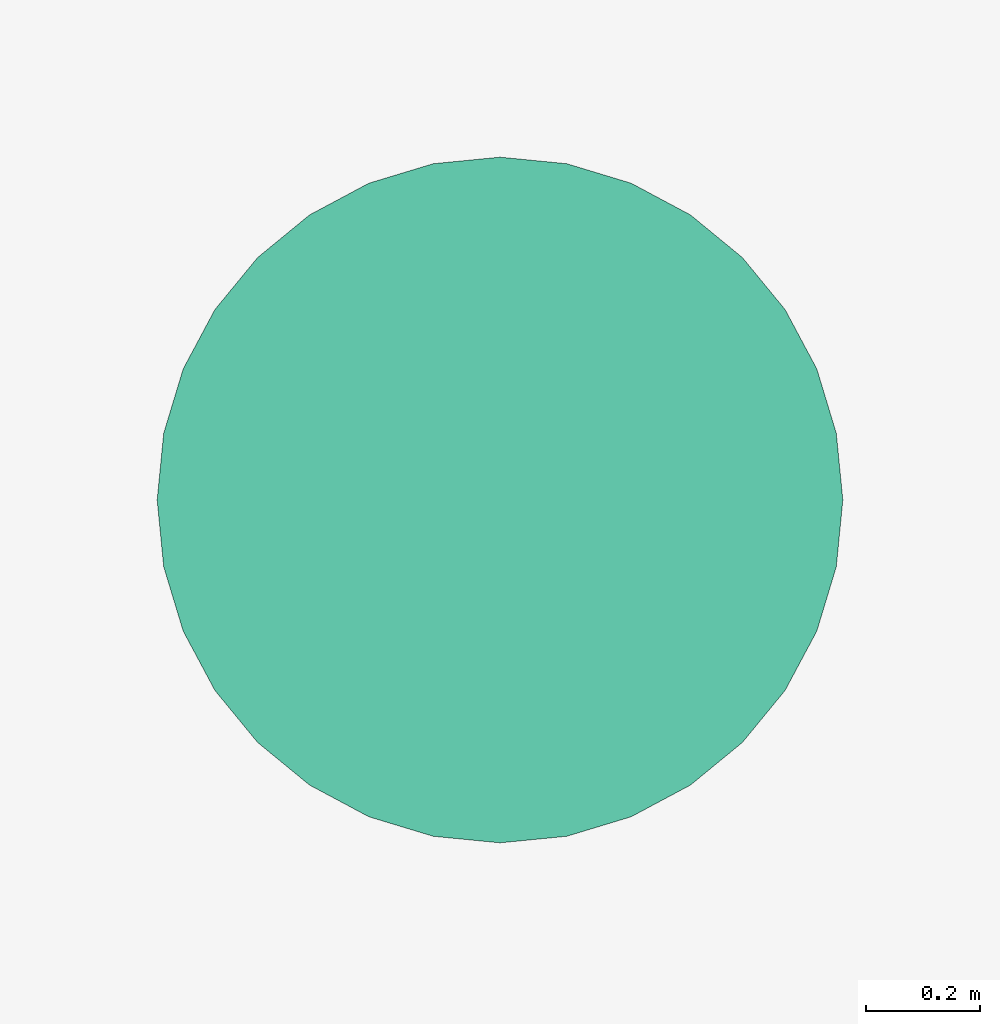
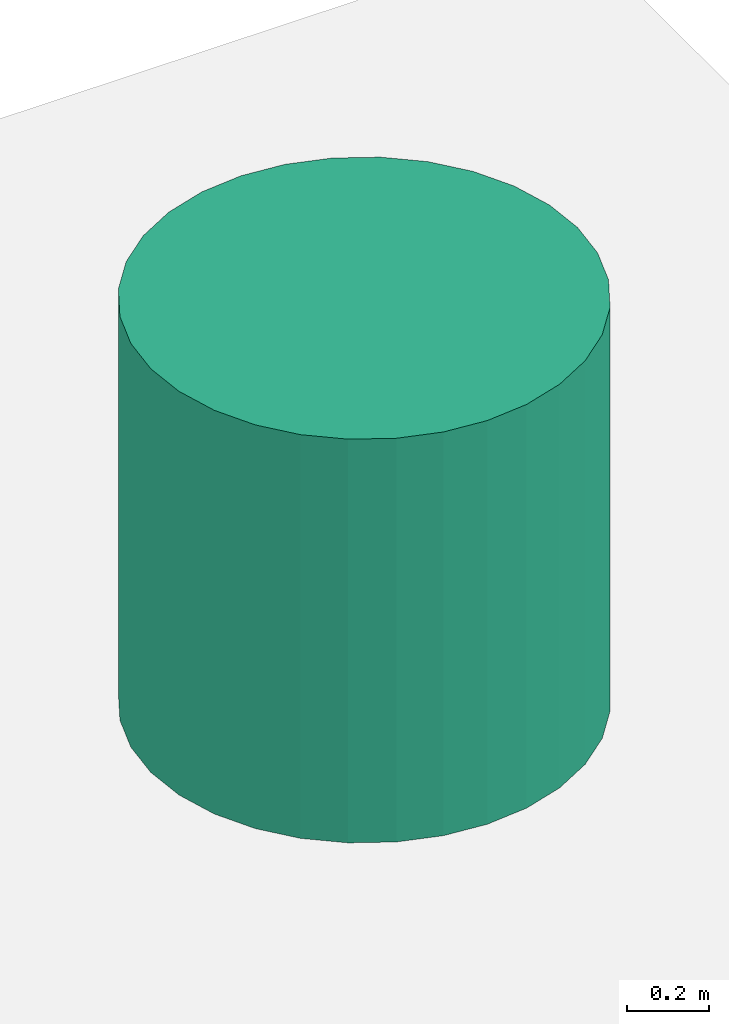
# One storey, part 2 of 2: 1 tank.
"""IFC4X3_ADD2 building model written with IfcOpenShell, lengths in metres."""

from ifc_helpers import new_model, entity, si_unit, converted_unit, frame, origin_with_axes, origin_2d_with_axis, place, context, subcontext, project, spatial, polygons, source, transform, mapped, type_object, type_shapes, element, save


model = new_model("IFC4X3_ADD2")

# Units and contexts
model_context = context("Model", 3, precision=1e-05, world=origin_with_axes())
plan_context = context("Plan", 2, precision=1e-05, world=origin_2d_with_axis())
body_context = subcontext(model_context, "Body", "Model", "MODEL_VIEW")
ifc_project = project(units=[si_unit("VOLUMEUNIT", "CUBIC_METRE"), si_unit("LENGTHUNIT", "METRE"), converted_unit("PLANEANGLEUNIT", "degree", entity("IfcReal", 0.0174532925199433), si_unit("PLANEANGLEUNIT", "RADIAN"), dimensions=[0, 0, 0, 0, 0, 0, 0]), si_unit("AREAUNIT", "SQUARE_METRE")], contexts=[model_context, plan_context])

# Site, building, storey
site_placement = place(None, origin_with_axes())
site = spatial("IfcSite", under=ifc_project, at=site_placement)
building_placement = place(site_placement, origin_with_axes())
building = spatial("IfcBuilding", under=site, at=building_placement, Name="Building")
storey_placement = place(building_placement, frame((0.0, 0.0, 5.69999980926514), z_axis=(0.0, 0.0, 1.0), x_axis=(1.0, 0.0, 0.0)))
storey = spatial("IfcBuildingStorey", under=building, at=storey_placement)

# Tank
tank_type = type_object("IfcTankType", Name="WaterTank_1000L", PredefinedType="STORAGE")
shared_shape = source(origin_with_axes(), body_context, "Body", "Tessellation", [
    polygons([(0.0, 0.600000023841858, 0.0), (0.0, 0.600000023841858, 1.20000004768372), (0.11705420166254, 0.588471174240112, 0.0), (0.11705420166254, 0.588471174240112, 1.20000004768372), (0.229610085487366, 0.554327726364136, 0.0), (0.229610085487366, 0.554327726364136, 1.20000004768372), (0.333342164754868, 0.498881787061691, 0.0), (0.333342164754868, 0.498881787061691, 1.20000004768372), (0.424264073371887, 0.424264073371887, 0.0), (0.424264073371887, 0.424264073371887, 1.20000004768372), (0.498881787061691, 0.333342164754868, 0.0), (0.498881787061691, 0.333342164754868, 1.20000004768372), (0.554327726364136, 0.229610085487366, 0.0), (0.554327726364136, 0.229610085487366, 1.20000004768372), (0.588471174240112, 0.11705420166254, 0.0), (0.588471174240112, 0.11705420166254, 1.20000004768372), (0.600000023841858, 0.0, 0.0), (0.600000023841858, 0.0, 1.20000004768372), (0.588471174240112, -0.11705420166254, 0.0), (0.588471174240112, -0.11705420166254, 1.20000004768372), (0.554327726364136, -0.229610085487366, 0.0), (0.554327726364136, -0.229610085487366, 1.20000004768372), (0.498881787061691, -0.333342164754868, 0.0), (0.498881787061691, -0.333342164754868, 1.20000004768372), (0.424264073371887, -0.424264073371887, 0.0), (0.424264073371887, -0.424264073371887, 1.20000004768372), (0.333342164754868, -0.498881787061691, 0.0), (0.333342164754868, -0.498881787061691, 1.20000004768372), (0.229610085487366, -0.554327726364136, 0.0), (0.229610085487366, -0.554327726364136, 1.20000004768372), (0.11705420166254, -0.588471174240112, 0.0), (0.11705420166254, -0.588471174240112, 1.20000004768372), (0.0, -0.600000023841858, 0.0), (0.0, -0.600000023841858, 1.20000004768372), (-0.11705420166254, -0.588471174240112, 0.0), (-0.11705420166254, -0.588471174240112, 1.20000004768372), (-0.229610085487366, -0.554327726364136, 0.0), (-0.229610085487366, -0.554327726364136, 1.20000004768372), (-0.333342164754868, -0.498881787061691, 0.0), (-0.333342164754868, -0.498881787061691, 1.20000004768372), (-0.424264073371887, -0.424264073371887, 0.0), (-0.424264073371887, -0.424264073371887, 1.20000004768372), (-0.498881787061691, -0.333342164754868, 0.0), (-0.498881787061691, -0.333342164754868, 1.20000004768372), (-0.554327726364136, -0.229610085487366, 0.0), (-0.554327726364136, -0.229610085487366, 1.20000004768372), (-0.588471174240112, -0.11705420166254, 0.0), (-0.588471174240112, -0.11705420166254, 1.20000004768372), (-0.600000023841858, 0.0, 0.0), (-0.600000023841858, 0.0, 1.20000004768372), (-0.588471174240112, 0.11705420166254, 0.0), (-0.588471174240112, 0.11705420166254, 1.20000004768372), (-0.554327726364136, 0.229610085487366, 0.0), (-0.554327726364136, 0.229610085487366, 1.20000004768372), (-0.498881787061691, 0.333342164754868, 0.0), (-0.498881787061691, 0.333342164754868, 1.20000004768372), (-0.424264073371887, 0.424264073371887, 0.0), (-0.424264073371887, 0.424264073371887, 1.20000004768372), (-0.333342164754868, 0.498881787061691, 0.0), (-0.333342164754868, 0.498881787061691, 1.20000004768372), (-0.229610085487366, 0.554327726364136, 0.0), (-0.229610085487366, 0.554327726364136, 1.20000004768372), (-0.11705420166254, 0.588471174240112, 0.0), (-0.11705420166254, 0.588471174240112, 1.20000004768372)], [[[1, 2, 4, 3]], [[3, 4, 6, 5]], [[5, 6, 8, 7]], [[7, 8, 10, 9]], [[9, 10, 12, 11]], [[11, 12, 14, 13]], [[13, 14, 16, 15]], [[15, 16, 18, 17]], [[17, 18, 20, 19]], [[19, 20, 22, 21]], [[21, 22, 24, 23]], [[23, 24, 26, 25]], [[25, 26, 28, 27]], [[27, 28, 30, 29]], [[29, 30, 32, 31]], [[31, 32, 34, 33]], [[33, 34, 36, 35]], [[35, 36, 38, 37]], [[37, 38, 40, 39]], [[39, 40, 42, 41]], [[41, 42, 44, 43]], [[43, 44, 46, 45]], [[45, 46, 48, 47]], [[47, 48, 50, 49]], [[49, 50, 52, 51]], [[51, 52, 54, 53]], [[53, 54, 56, 55]], [[55, 56, 58, 57]], [[57, 58, 60, 59]], [[59, 60, 62, 61]], [[4, 2, 64, 62, 60, 58, 56, 54, 52, 50, 48, 46, 44, 42, 40, 38, 36, 34, 32, 30, 28, 26, 24, 22, 20, 18, 16, 14, 12, 10, 8, 6]], [[61, 62, 64, 63]], [[63, 64, 2, 1]], [[1, 3, 5, 7, 9, 11, 13, 15, 17, 19, 21, 23, 25, 27, 29, 31, 33, 35, 37, 39, 41, 43, 45, 47, 49, 51, 53, 55, 57, 59, 61, 63]]]),
])
type_shapes(tank_type, [shared_shape])
tank_placement = place(storey_placement, frame((22.6876373291016, 21.1401405334473, 0.809999942779537), z_axis=(0.0, 0.0, 1.0), x_axis=(1.0, 0.0, 0.0)))
element("IfcTank", 1, at=tank_placement, inside=storey, type_object=tank_type, Name="Tank", context=body_context, shape_type="MappedRepresentation", body=[
    mapped(shared_shape, transform((0.0, 0.0, 0.0), x_axis=(1.0, 0.0, 0.0), y_axis=(0.0, 1.0, 0.0), z_axis=(0.0, 0.0, 1.0), scale=1.0)),
])

save(model, "model.ifc")
